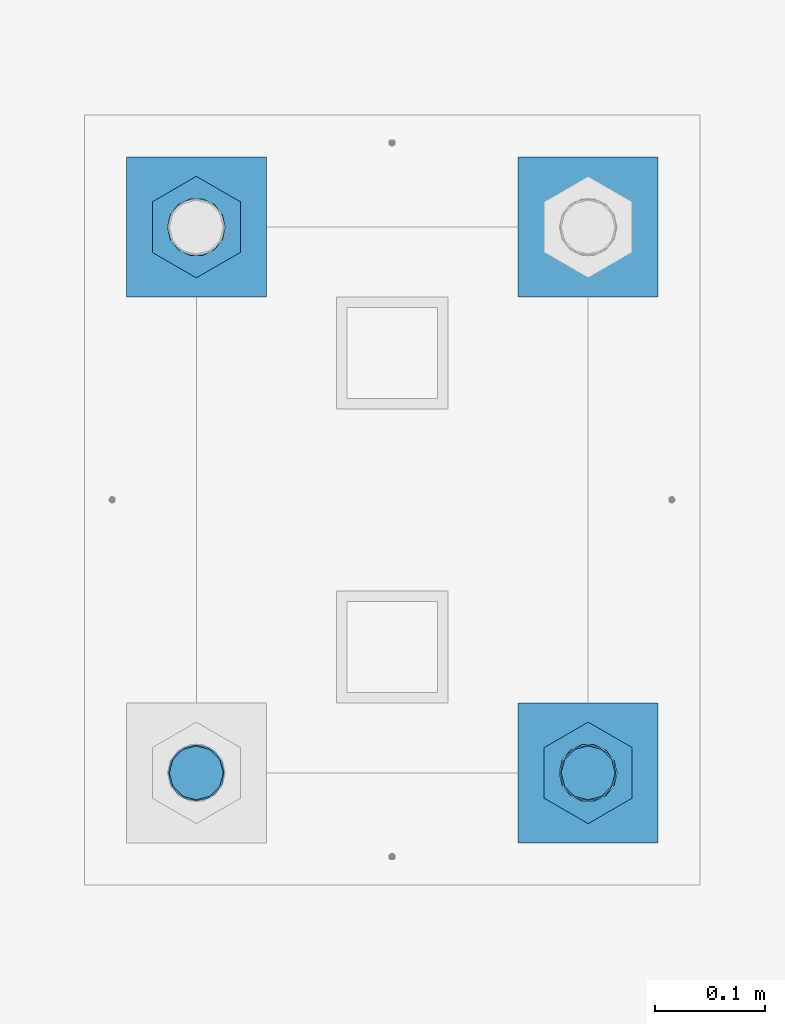
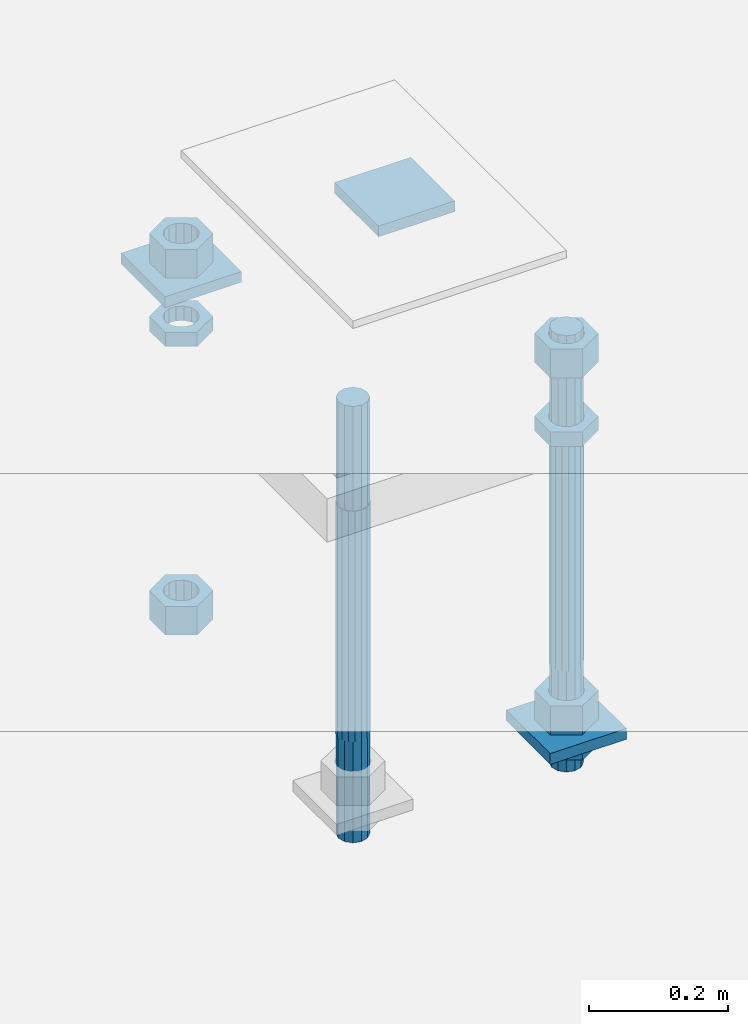
# One storey, part 2766 of 3843: 12 beams, 1 element without a shape of its own.
"""IFC2X3 building model written with IfcOpenShell, lengths in millimetres."""

import ifcopenshell
import ifcopenshell.guid

model = None  # the IFC model being written
_history = None  # IfcOwnerHistory: only IFC2X3 demands one
_inside = {}  # id of a spatial element -> (the spatial element, [elements in it])
_under = {}  # id of a project, library or spatial element -> (it, [spatial elements below it])
_declared = {}  # id of a project -> (the project, [libraries it declares])
_typed = {}  # id of a type object -> (the type object, [elements of that type])
_made_of = {}  # id of a material, layer set ... -> (it, [elements and type objects made of it])


def new_model(schema):
    """Start an empty IFC model of exactly this schema.

    Asked for "IFC4X3", IfcOpenShell would pick the latest addendum, in which some entities
    have other attributes; the version numbers below select the first issue.
    IFC2X3 requires an IfcOwnerHistory on every rooted entity: one is made here for all.
    """
    global model, _history
    if schema == "IFC4X3":
        model = ifcopenshell.file(schema_version=(4, 3, 0, 0))
    else:
        model = ifcopenshell.file(schema=schema)
    _inside.clear()
    _under.clear()
    _declared.clear()
    _typed.clear()
    _made_of.clear()
    _history = None
    if model.schema == "IFC2X3":
        org = make("IfcOrganization", Name="unknown")
        user = make(
            "IfcPersonAndOrganization",
            ThePerson=make("IfcPerson", FamilyName="unknown"),
            TheOrganization=org,
        )
        app = make(
            "IfcApplication",
            ApplicationDeveloper=org,
            Version="unknown",
            ApplicationFullName="unknown",
            ApplicationIdentifier="unknown",
        )
        _history = make(
            "IfcOwnerHistory",
            OwningUser=user,
            OwningApplication=app,
            ChangeAction="ADDED",
            CreationDate=0,
        )
    return model


def make(cls, **values):
    """One entity of the class cls with the attributes given. An attribute that is None is left unset."""
    return model.create_entity(
        cls, **{name: value for name, value in values.items() if value is not None}
    )


def rooted(cls, **values):
    """An entity with a GlobalId (a new one), such as an element, a storey or a relation."""
    return make(cls, GlobalId=ifcopenshell.guid.new(), OwnerHistory=_history, **values)


def si_unit(unit_type, name, prefix=None):
    """IfcSIUnit, for example si_unit("LENGTHUNIT", "METRE", prefix="MILLI")."""
    return make("IfcSIUnit", UnitType=unit_type, Prefix=prefix, Name=name)


def assignment(units):
    """IfcUnitAssignment: the units of a project."""
    return None if units is None else make("IfcUnitAssignment", Units=units)


def point(xyz):
    """IfcCartesianPoint."""
    return None if xyz is None else make("IfcCartesianPoint", Coordinates=xyz)


def direction(xyz):
    """IfcDirection."""
    return None if xyz is None else make("IfcDirection", DirectionRatios=xyz)


def frame(location, z_axis=None, x_axis=None):
    """IfcAxis2Placement3D, a coordinate frame: its origin and axes. An axis left out is left unset."""
    return make(
        "IfcAxis2Placement3D",
        Location=point(location),
        Axis=direction(z_axis),
        RefDirection=direction(x_axis),
    )


def origin_with_axes():
    """The frame at (0, 0, 0) with the z axis (0, 0, 1) and the x axis (1, 0, 0) written out."""
    return frame((0.0, 0.0, 0.0), z_axis=(0.0, 0.0, 1.0), x_axis=(1.0, 0.0, 0.0))


def place(relative_to, where):
    """IfcLocalPlacement: puts the frame where relative to a parent placement (None: the world)."""
    return make(
        "IfcLocalPlacement", PlacementRelTo=relative_to, RelativePlacement=where
    )


def context(
    kind, dimensions, precision=None, world=None, true_north=None, identifier=None
):
    """IfcGeometricRepresentationContext, for example the 3D "Model" context."""
    return make(
        "IfcGeometricRepresentationContext",
        ContextIdentifier=identifier,
        ContextType=kind,
        CoordinateSpaceDimension=dimensions,
        Precision=precision,
        WorldCoordinateSystem=world,
        TrueNorth=true_north,
    )


def subcontext(parent, identifier, kind, view, scale=None):
    """IfcGeometricRepresentationSubContext, for example "Body" below "Model"."""
    return make(
        "IfcGeometricRepresentationSubContext",
        ContextIdentifier=identifier,
        ContextType=kind,
        ParentContext=parent,
        TargetScale=scale,
        TargetView=view,
    )


def project(units=None, contexts=None):
    """IfcProject with its units and contexts."""
    return rooted(
        "IfcProject",
        Name="project",
        RepresentationContexts=contexts,
        UnitsInContext=assignment(units),
    )


def spatial(cls, under=None, at=None, **own):
    """A site, building, storey or space (cls), placed at a placement, below another one or the project."""
    s = rooted(cls, ObjectPlacement=at, **own)
    if under is not None:
        _under.setdefault(under.id(), (under, []))[1].append(s)
    return s


def faces_of(points, faces, orient=None, outer=None):
    """IfcFace entities. A face is a list of loops; a loop is a list of indices into points, from 0.

    orient and outer hold one flag for each loop. By default every Orientation is true, the
    first loop of a face is its IfcFaceOuterBound and the others are IfcFaceBound.
    """
    made = []
    for i, loops in enumerate(faces):
        bounds = []
        for j, loop in enumerate(loops):
            is_outer = j == 0 if outer is None else outer[i][j]
            bounds.append(
                make(
                    "IfcFaceOuterBound" if is_outer else "IfcFaceBound",
                    Bound=make("IfcPolyLoop", Polygon=[points[k] for k in loop]),
                    Orientation=True if orient is None else orient[i][j],
                )
            )
        made.append(make("IfcFace", Bounds=bounds))
    return made


def faceted_brep(points, faces, orient=None, outer=None, voids=None):
    """IfcFacetedBrep: a solid bounded by flat faces; with voids (closed shells), ...WithVoids."""
    shared = [point(p) for p in points]
    hull = make("IfcClosedShell", CfsFaces=faces_of(shared, faces, orient, outer))
    if voids is None:
        return make("IfcFacetedBrep", Outer=hull)
    return make(
        "IfcFacetedBrepWithVoids",
        Outer=hull,
        Voids=[
            make(cls, CfsFaces=faces_of(shared, fs, o, b)) for cls, fs, o, b in voids
        ],
    )


def shape(context_of_items, identifier, shape_type, items):
    """IfcShapeRepresentation: the items that make up one representation, for example the "Body"."""
    return make(
        "IfcShapeRepresentation",
        ContextOfItems=context_of_items,
        RepresentationIdentifier=identifier,
        RepresentationType=shape_type,
        Items=items,
    )


def material(Name=None, Category=None):
    """IfcMaterial."""
    return make("IfcMaterial", Name=Name, Category=Category)


def made_of(thing, what):
    """Note that an element or type object is made of a material, layer set ...; save() writes the relation."""
    if what is not None:
        _made_of.setdefault(what.id(), (what, []))[1].append(thing)
    return thing


def type_object(cls, material=None, **own):
    """A type object (cls), such as IfcWallType, which elements share."""
    return made_of(rooted(cls, **own), material)


def element(
    cls,
    number,
    at=None,
    inside=None,
    cuts=None,
    type_object=None,
    material=None,
    context=None,
    identifier="Body",
    shape_type=None,
    held_by="IfcProductDefinitionShape",
    body=None,
    shapes=None,
    **own,
):
    """One element of the class cls, such as IfcWall. Its Tag is "e" and its number.

    at: its placement. inside: the storey or other place that contains it. cuts: it is an
    opening in that element (IfcRelVoidsElement). A single representation is given by context,
    identifier, shape_type and body (its items); several are given by shapes. held_by: the class
    of the entity that holds the representations. save() writes the other relations.
    """
    e = rooted(cls, Tag="e%d" % number, ObjectPlacement=at, **own)
    if body is not None:
        shapes = [shape(context, identifier, shape_type, body)]
    if shapes is not None:
        e.Representation = make(held_by, Representations=shapes)
    if inside is not None:
        _inside.setdefault(inside.id(), (inside, []))[1].append(e)
    if cuts is not None:
        rooted(
            "IfcRelVoidsElement", RelatingBuildingElement=cuts, RelatedOpeningElement=e
        )
    if type_object is not None:
        _typed.setdefault(type_object.id(), (type_object, []))[1].append(e)
    return made_of(e, material)


def aggregate(whole, parts):
    """IfcRelAggregates: a whole, such as a stair, and the parts it consists of."""
    return rooted("IfcRelAggregates", RelatingObject=whole, RelatedObjects=parts)


def save(model, path):
    """Write the relations noted so far, then the file.

    IfcRelAggregates (storeys below a building ...), IfcRelContainedInSpatialStructure (elements
    in a storey), IfcRelDefinesByType, IfcRelAssociatesMaterial and IfcRelDeclares: one each for
    every whole, place, type object, material and project.
    """
    for whole, parts in _under.values():
        aggregate(whole, parts)
    for where, things in _inside.values():
        rooted(
            "IfcRelContainedInSpatialStructure",
            RelatedElements=things,
            RelatingStructure=where,
        )
    for kind, things in _typed.values():
        rooted("IfcRelDefinesByType", RelatedObjects=things, RelatingType=kind)
    for what, things in _made_of.values():
        rooted("IfcRelAssociatesMaterial", RelatedObjects=things, RelatingMaterial=what)
    for by, libraries in _declared.values():
        rooted("IfcRelDeclares", RelatingContext=by, RelatedDefinitions=libraries)
    model.write(path)


model = new_model("IFC2X3")

# Units and contexts
model_context = context("Model", 3, precision=1e-05, world=origin_with_axes())
body_context = subcontext(model_context, "Body", "Model", "MODEL_VIEW")
ifc_project = project(units=[si_unit("LENGTHUNIT", "METRE", prefix="MILLI"), si_unit("AREAUNIT", "SQUARE_METRE"), si_unit("VOLUMEUNIT", "CUBIC_METRE"), si_unit("MASSUNIT", "GRAM", prefix="KILO"), si_unit("TIMEUNIT", "SECOND"), si_unit("PLANEANGLEUNIT", "RADIAN"), si_unit("SOLIDANGLEUNIT", "STERADIAN"), si_unit("THERMODYNAMICTEMPERATUREUNIT", "DEGREE_CELSIUS"), si_unit("LUMINOUSINTENSITYUNIT", "LUMEN")], contexts=[model_context])

# Site, building, storey
site_placement = place(None, origin_with_axes())
site = spatial("IfcSite", under=ifc_project, at=site_placement, CompositionType="ELEMENT")
building_placement = place(site_placement, origin_with_axes())
building = spatial("IfcBuilding", under=site, at=building_placement, Name="Undefined", CompositionType="ELEMENT")
storey_placement = place(building_placement, origin_with_axes())
storey = spatial("IfcBuildingStorey", under=building, at=storey_placement, Name="Undefined", CompositionType="ELEMENT", Elevation=0.0)

# Assembly, beams
assembly_placement = place(storey_placement, origin_with_axes())
assembly = element("IfcElementAssembly", 1, at=assembly_placement, inside=storey, Name="TEMPLATE", AssemblyPlace="NOTDEFINED", PredefinedType="RIGID_FRAME")
ifc_material_1 = material(Name="STEEL/A572-50")
beam_type_1 = type_object("IfcBeamType", PredefinedType="NOTDEFINED")
beam_1_placement = place(assembly_placement, frame((115862.100001526, 52952.65, 29873.575), z_axis=(0.0, -1.0, 0.0), x_axis=(1.0, 0.0, 0.0)))
beam_1 = element("IfcBeam", 2, at=beam_1_placement, type_object=beam_type_1, material=ifc_material_1, Name="WASHER_PLATE", context=body_context, shape_type="Brep", body=[
    faceted_brep([(0.0, 9.52500000000146, -63.5), (0.0, 9.52500000000146, 63.5), (127.0, 9.52500000000146, 63.5), (127.0, 9.52500000000146, -63.5), (0.0, -9.52500000000146, 63.5), (127.0, -9.52500000000146, 63.5), (0.0, -9.52500000000146, -63.5), (127.0, -9.52500000000146, -63.5)], [[[0, 1, 2, 3]], [[1, 4, 5, 2]], [[4, 6, 7, 5]], [[6, 0, 3, 7]], [[5, 7, 3, 2]], [[6, 4, 1, 0]]]),
])
beam_2_placement = place(assembly_placement, frame((116217.700001526, 52952.65, 29873.575), z_axis=(0.0, -1.0, 0.0), x_axis=(1.0, 0.0, 0.0)))
beam_2 = element("IfcBeam", 3, at=beam_2_placement, type_object=beam_type_1, material=ifc_material_1, Name="WASHER_PLATE", context=body_context, shape_type="Brep", body=[
    faceted_brep([(0.0, 9.52500000000146, -63.5), (0.0, 9.52500000000146, 63.5), (127.0, 9.52500000000146, 63.5), (127.0, 9.52500000000146, -63.5), (0.0, -9.52500000000146, 63.5), (127.0, -9.52500000000146, 63.5), (0.0, -9.52500000000146, -63.5), (127.0, -9.52500000000146, -63.5)], [[[0, 1, 2, 3]], [[1, 4, 5, 2]], [[4, 6, 7, 5]], [[6, 0, 3, 7]], [[5, 7, 3, 2]], [[6, 4, 1, 0]]]),
])
beam_3_placement = place(assembly_placement, frame((116217.700001526, 52457.35, 29244.925), z_axis=(0.0, -1.0, 0.0), x_axis=(1.0, 0.0, 0.0)))
beam_3 = element("IfcBeam", 4, at=beam_3_placement, type_object=beam_type_1, material=ifc_material_1, Name="WASHER_PLATE", context=body_context, shape_type="Brep", body=[
    faceted_brep([(0.0, 9.52500000000146, -63.5), (0.0, 9.52500000000146, 63.5), (127.0, 9.52500000000146, 63.5), (127.0, 9.52500000000146, -63.5), (0.0, -9.52500000000146, 63.5), (127.0, -9.52500000000146, 63.5), (0.0, -9.52500000000146, -63.5), (127.0, -9.52500000000146, -63.5)], [[[0, 1, 2, 3]], [[1, 4, 5, 2]], [[4, 6, 7, 5]], [[6, 0, 3, 7]], [[5, 7, 3, 2]], [[6, 4, 1, 0]]]),
])
ifc_material_2 = material(Name="STEEL/A36")
beam_type_2 = type_object("IfcBeamType", Name="2_HALF_NUT", PredefinedType="NOTDEFINED")
beam_4_placement = place(assembly_placement, frame((115925.600001526, 52952.65, 29787.85), z_axis=(1.0, 0.0, 0.0), x_axis=(0.0, 0.0, -1.0)))
beam_4 = element("IfcBeam", 5, at=beam_4_placement, type_object=beam_type_2, material=ifc_material_2, Name="NUT", ObjectType="2_HALF_NUT", context=body_context, shape_type="Brep", body=[
    faceted_brep([(0.0, -46.0369987487793, 0.0), (0.0, -23.0184993743896, -39.869213104248), (25.4000000000015, -23.0184993743896, -39.869213104248), (25.4000000000015, -46.0369987487793, 0.0), (0.0, 23.0184993743896, -39.869213104248), (25.4000000000015, 23.0184993743896, -39.869213104248), (0.0, 46.0369987487793, 0.0), (25.4000000000015, 46.0369987487793, 0.0), (0.0, 23.0184993743896, 39.869213104248), (25.4000000000015, 23.0184993743896, 39.869213104248), (0.0, -23.0184993743896, 39.869213104248), (25.4000000000015, -23.0184993743896, 39.869213104248), (0.0, 0.0, 26.1940002441406), (0.0, 11.3650617044477, 23.5999013092805), (25.4000000000015, 11.3650617044477, 23.5999013092805), (25.4000000000015, 0.0, 26.1940002441406), (0.0, 20.4791109456419, 16.3316083006721), (25.4000000000015, 20.4791109456419, 16.3316083006721), (0.0, 25.5370200498292, 5.82867859874386), (25.4000000000015, 25.5370200498292, 5.82867859874386), (0.0, 25.5370200498292, -5.82867859874386), (25.4000000000015, 25.5370200498292, -5.82867859874386), (0.0, 20.4791109456419, -16.3316083006721), (25.4000000000015, 20.4791109456419, -16.3316083006721), (0.0, 11.3650617044477, -23.5999013092805), (25.4000000000015, 11.3650617044477, -23.5999013092805), (0.0, 0.0, -26.1940002441406), (25.4000000000015, 0.0, -26.1940002441406), (0.0, -11.3650617044477, -23.5999013092805), (25.4000000000015, -11.3650617044477, -23.5999013092805), (0.0, -20.4791109456419, -16.3316083006721), (25.4000000000015, -20.4791109456419, -16.3316083006721), (0.0, -25.5370200498292, -5.82867859874386), (25.4000000000015, -25.5370200498292, -5.82867859874386), (0.0, -25.5370200498292, 5.82867859874386), (25.4000000000015, -25.5370200498292, 5.82867859874386), (0.0, -20.4791109456419, 16.3316083006721), (25.4000000000015, -20.4791109456419, 16.3316083006721), (0.0, -11.3650617044477, 23.5999013092805), (25.4000000000015, -11.3650617044477, 23.5999013092805)], [[[0, 1, 2, 3]], [[1, 4, 5, 2]], [[4, 6, 7, 5]], [[6, 8, 9, 7]], [[8, 10, 11, 9]], [[10, 0, 3, 11]], [[12, 13, 14, 15]], [[13, 16, 17, 14]], [[16, 18, 19, 17]], [[18, 20, 21, 19]], [[20, 22, 23, 21]], [[22, 24, 25, 23]], [[24, 26, 27, 25]], [[26, 28, 29, 27]], [[28, 30, 31, 29]], [[30, 32, 33, 31]], [[32, 34, 35, 33]], [[34, 36, 37, 35]], [[36, 38, 39, 37]], [[38, 12, 15, 39]], [[5, 7, 9, 11, 3, 2], [17, 19, 21, 23, 25, 27, 29, 31, 33, 35, 37, 39, 15, 14]], [[10, 8, 6, 4, 1, 0], [38, 36, 34, 32, 30, 28, 26, 24, 22, 20, 18, 16, 13, 12]]]),
])
beam_5_placement = place(assembly_placement, frame((116281.200001526, 52457.35, 29787.85), z_axis=(1.0, 0.0, 0.0), x_axis=(0.0, 0.0, -1.0)))
beam_5 = element("IfcBeam", 6, at=beam_5_placement, type_object=beam_type_2, material=ifc_material_2, Name="NUT", ObjectType="2_HALF_NUT", context=body_context, shape_type="Brep", body=[
    faceted_brep([(0.0, -46.0369987487793, 0.0), (0.0, -23.0184993743896, -39.869213104248), (25.4000000000015, -23.0184993743896, -39.869213104248), (25.4000000000015, -46.0369987487793, 0.0), (0.0, 23.0184993743896, -39.869213104248), (25.4000000000015, 23.0184993743896, -39.869213104248), (0.0, 46.0369987487793, 0.0), (25.4000000000015, 46.0369987487793, 0.0), (0.0, 23.0184993743896, 39.869213104248), (25.4000000000015, 23.0184993743896, 39.869213104248), (0.0, -23.0184993743896, 39.869213104248), (25.4000000000015, -23.0184993743896, 39.869213104248), (0.0, 0.0, 26.1940002441406), (0.0, 11.3650617044477, 23.5999013092805), (25.4000000000015, 11.3650617044477, 23.5999013092805), (25.4000000000015, 0.0, 26.1940002441406), (0.0, 20.4791109456419, 16.3316083006721), (25.4000000000015, 20.4791109456419, 16.3316083006721), (0.0, 25.5370200498292, 5.82867859874386), (25.4000000000015, 25.5370200498292, 5.82867859874386), (0.0, 25.5370200498292, -5.82867859874386), (25.4000000000015, 25.5370200498292, -5.82867859874386), (0.0, 20.4791109456419, -16.3316083006721), (25.4000000000015, 20.4791109456419, -16.3316083006721), (0.0, 11.3650617044477, -23.5999013092805), (25.4000000000015, 11.3650617044477, -23.5999013092805), (0.0, 0.0, -26.1940002441406), (25.4000000000015, 0.0, -26.1940002441406), (0.0, -11.3650617044477, -23.5999013092805), (25.4000000000015, -11.3650617044477, -23.5999013092805), (0.0, -20.4791109456419, -16.3316083006721), (25.4000000000015, -20.4791109456419, -16.3316083006721), (0.0, -25.5370200498292, -5.82867859874386), (25.4000000000015, -25.5370200498292, -5.82867859874386), (0.0, -25.5370200498292, 5.82867859874386), (25.4000000000015, -25.5370200498292, 5.82867859874386), (0.0, -20.4791109456419, 16.3316083006721), (25.4000000000015, -20.4791109456419, 16.3316083006721), (0.0, -11.3650617044477, 23.5999013092805), (25.4000000000015, -11.3650617044477, 23.5999013092805)], [[[0, 1, 2, 3]], [[1, 4, 5, 2]], [[4, 6, 7, 5]], [[6, 8, 9, 7]], [[8, 10, 11, 9]], [[10, 0, 3, 11]], [[12, 13, 14, 15]], [[13, 16, 17, 14]], [[16, 18, 19, 17]], [[18, 20, 21, 19]], [[20, 22, 23, 21]], [[22, 24, 25, 23]], [[24, 26, 27, 25]], [[26, 28, 29, 27]], [[28, 30, 31, 29]], [[30, 32, 33, 31]], [[32, 34, 35, 33]], [[34, 36, 37, 35]], [[36, 38, 39, 37]], [[38, 12, 15, 39]], [[5, 7, 9, 11, 3, 2], [17, 19, 21, 23, 25, 27, 29, 31, 33, 35, 37, 39, 15, 14]], [[10, 8, 6, 4, 1, 0], [38, 36, 34, 32, 30, 28, 26, 24, 22, 20, 18, 16, 13, 12]]]),
])
beam_6_placement = place(assembly_placement, frame((116281.200001526, 52457.35, 29235.4), z_axis=(1.0, 0.0, 0.0), x_axis=(0.0, 0.0, -1.0)))
beam_6 = element("IfcBeam", 7, at=beam_6_placement, type_object=beam_type_2, material=ifc_material_2, Name="NUT", ObjectType="2_HALF_NUT", context=body_context, shape_type="Brep", body=[
    faceted_brep([(0.0, -46.0369987487793, 0.0), (0.0, -23.0184993743896, -39.869213104248), (25.4000000000015, -23.0184993743896, -39.869213104248), (25.4000000000015, -46.0369987487793, 0.0), (0.0, 23.0184993743896, -39.869213104248), (25.4000000000015, 23.0184993743896, -39.869213104248), (0.0, 46.0369987487793, 0.0), (25.4000000000015, 46.0369987487793, 0.0), (0.0, 23.0184993743896, 39.869213104248), (25.4000000000015, 23.0184993743896, 39.869213104248), (0.0, -23.0184993743896, 39.869213104248), (25.4000000000015, -23.0184993743896, 39.869213104248), (0.0, 0.0, 26.1940002441406), (0.0, 11.3650617044477, 23.5999013092805), (25.4000000000015, 11.3650617044477, 23.5999013092805), (25.4000000000015, 0.0, 26.1940002441406), (0.0, 20.4791109456419, 16.3316083006721), (25.4000000000015, 20.4791109456419, 16.3316083006721), (0.0, 25.5370200498292, 5.82867859874386), (25.4000000000015, 25.5370200498292, 5.82867859874386), (0.0, 25.5370200498292, -5.82867859874386), (25.4000000000015, 25.5370200498292, -5.82867859874386), (0.0, 20.4791109456419, -16.3316083006721), (25.4000000000015, 20.4791109456419, -16.3316083006721), (0.0, 11.3650617044477, -23.5999013092805), (25.4000000000015, 11.3650617044477, -23.5999013092805), (0.0, 0.0, -26.1940002441406), (25.4000000000015, 0.0, -26.1940002441406), (0.0, -11.3650617044477, -23.5999013092805), (25.4000000000015, -11.3650617044477, -23.5999013092805), (0.0, -20.4791109456419, -16.3316083006721), (25.4000000000015, -20.4791109456419, -16.3316083006721), (0.0, -25.5370200498292, -5.82867859874386), (25.4000000000015, -25.5370200498292, -5.82867859874386), (0.0, -25.5370200498292, 5.82867859874386), (25.4000000000015, -25.5370200498292, 5.82867859874386), (0.0, -20.4791109456419, 16.3316083006721), (25.4000000000015, -20.4791109456419, 16.3316083006721), (0.0, -11.3650617044477, 23.5999013092805), (25.4000000000015, -11.3650617044477, 23.5999013092805)], [[[0, 1, 2, 3]], [[1, 4, 5, 2]], [[4, 6, 7, 5]], [[6, 8, 9, 7]], [[8, 10, 11, 9]], [[10, 0, 3, 11]], [[12, 13, 14, 15]], [[13, 16, 17, 14]], [[16, 18, 19, 17]], [[18, 20, 21, 19]], [[20, 22, 23, 21]], [[22, 24, 25, 23]], [[24, 26, 27, 25]], [[26, 28, 29, 27]], [[28, 30, 31, 29]], [[30, 32, 33, 31]], [[32, 34, 35, 33]], [[34, 36, 37, 35]], [[36, 38, 39, 37]], [[38, 12, 15, 39]], [[5, 7, 9, 11, 3, 2], [17, 19, 21, 23, 25, 27, 29, 31, 33, 35, 37, 39, 15, 14]], [[10, 8, 6, 4, 1, 0], [38, 36, 34, 32, 30, 28, 26, 24, 22, 20, 18, 16, 13, 12]]]),
])
beam_type_3 = type_object("IfcBeamType", Name="2_HEAVY_HEX_NUT", PredefinedType="NOTDEFINED")
beam_7_placement = place(assembly_placement, frame((115925.600001526, 52952.65, 29933.9), z_axis=(1.0, 0.0, 0.0), x_axis=(0.0, 0.0, -1.0)))
beam_7 = element("IfcBeam", 8, at=beam_7_placement, type_object=beam_type_3, material=ifc_material_2, Name="NUT", ObjectType="2_HEAVY_HEX_NUT", context=body_context, shape_type="Brep", body=[
    faceted_brep([(0.0, -46.0369987487793, 0.0), (0.0, -23.0184993743896, -39.869213104248), (50.7999999999993, -23.0184993743896, -39.869213104248), (50.7999999999993, -46.0369987487793, 0.0), (0.0, 23.0184993743896, -39.869213104248), (50.7999999999993, 23.0184993743896, -39.869213104248), (0.0, 46.0369987487793, 0.0), (50.7999999999993, 46.0369987487793, 0.0), (0.0, 23.0184993743896, 39.869213104248), (50.7999999999993, 23.0184993743896, 39.869213104248), (0.0, -23.0184993743896, 39.869213104248), (50.7999999999993, -23.0184993743896, 39.869213104248), (0.0, 0.0, 26.1940002441406), (0.0, 11.3650617044477, 23.5999013092805), (50.7999999999993, 11.3650617044477, 23.5999013092805), (50.7999999999993, 0.0, 26.1940002441406), (0.0, 20.4791109456419, 16.3316083006721), (50.7999999999993, 20.4791109456419, 16.3316083006721), (0.0, 25.5370200498292, 5.82867859874386), (50.7999999999993, 25.5370200498292, 5.82867859874386), (0.0, 25.5370200498292, -5.82867859874386), (50.7999999999993, 25.5370200498292, -5.82867859874386), (0.0, 20.4791109456419, -16.3316083006721), (50.7999999999993, 20.4791109456419, -16.3316083006721), (0.0, 11.3650617044477, -23.5999013092805), (50.7999999999993, 11.3650617044477, -23.5999013092805), (0.0, 0.0, -26.1940002441406), (50.7999999999993, 0.0, -26.1940002441406), (0.0, -11.3650617044477, -23.5999013092805), (50.7999999999993, -11.3650617044477, -23.5999013092805), (0.0, -20.4791109456419, -16.3316083006721), (50.7999999999993, -20.4791109456419, -16.3316083006721), (0.0, -25.5370200498292, -5.82867859874386), (50.7999999999993, -25.5370200498292, -5.82867859874386), (0.0, -25.5370200498292, 5.82867859874386), (50.7999999999993, -25.5370200498292, 5.82867859874386), (0.0, -20.4791109456419, 16.3316083006721), (50.7999999999993, -20.4791109456419, 16.3316083006721), (0.0, -11.3650617044477, 23.5999013092805), (50.7999999999993, -11.3650617044477, 23.5999013092805)], [[[0, 1, 2, 3]], [[1, 4, 5, 2]], [[4, 6, 7, 5]], [[6, 8, 9, 7]], [[8, 10, 11, 9]], [[10, 0, 3, 11]], [[12, 13, 14, 15]], [[13, 16, 17, 14]], [[16, 18, 19, 17]], [[18, 20, 21, 19]], [[20, 22, 23, 21]], [[22, 24, 25, 23]], [[24, 26, 27, 25]], [[26, 28, 29, 27]], [[28, 30, 31, 29]], [[30, 32, 33, 31]], [[32, 34, 35, 33]], [[34, 36, 37, 35]], [[36, 38, 39, 37]], [[38, 12, 15, 39]], [[5, 7, 9, 11, 3, 2], [17, 19, 21, 23, 25, 27, 29, 31, 33, 35, 37, 39, 15, 14]], [[10, 8, 6, 4, 1, 0], [38, 36, 34, 32, 30, 28, 26, 24, 22, 20, 18, 16, 13, 12]]]),
])
beam_8_placement = place(assembly_placement, frame((115925.600001526, 52952.65, 29305.25), z_axis=(1.0, 0.0, 0.0), x_axis=(0.0, 0.0, -1.0)))
beam_8 = element("IfcBeam", 9, at=beam_8_placement, type_object=beam_type_3, material=ifc_material_2, Name="NUT", ObjectType="2_HEAVY_HEX_NUT", context=body_context, shape_type="Brep", body=[
    faceted_brep([(0.0, -46.0369987487793, 0.0), (0.0, -23.0184993743896, -39.869213104248), (50.7999999999993, -23.0184993743896, -39.869213104248), (50.7999999999993, -46.0369987487793, 0.0), (0.0, 23.0184993743896, -39.869213104248), (50.7999999999993, 23.0184993743896, -39.869213104248), (0.0, 46.0369987487793, 0.0), (50.7999999999993, 46.0369987487793, 0.0), (0.0, 23.0184993743896, 39.869213104248), (50.7999999999993, 23.0184993743896, 39.869213104248), (0.0, -23.0184993743896, 39.869213104248), (50.7999999999993, -23.0184993743896, 39.869213104248), (0.0, 0.0, 26.1940002441406), (0.0, 11.3650617044477, 23.5999013092805), (50.7999999999993, 11.3650617044477, 23.5999013092805), (50.7999999999993, 0.0, 26.1940002441406), (0.0, 20.4791109456419, 16.3316083006721), (50.7999999999993, 20.4791109456419, 16.3316083006721), (0.0, 25.5370200498292, 5.82867859874386), (50.7999999999993, 25.5370200498292, 5.82867859874386), (0.0, 25.5370200498292, -5.82867859874386), (50.7999999999993, 25.5370200498292, -5.82867859874386), (0.0, 20.4791109456419, -16.3316083006721), (50.7999999999993, 20.4791109456419, -16.3316083006721), (0.0, 11.3650617044477, -23.5999013092805), (50.7999999999993, 11.3650617044477, -23.5999013092805), (0.0, 0.0, -26.1940002441406), (50.7999999999993, 0.0, -26.1940002441406), (0.0, -11.3650617044477, -23.5999013092805), (50.7999999999993, -11.3650617044477, -23.5999013092805), (0.0, -20.4791109456419, -16.3316083006721), (50.7999999999993, -20.4791109456419, -16.3316083006721), (0.0, -25.5370200498292, -5.82867859874386), (50.7999999999993, -25.5370200498292, -5.82867859874386), (0.0, -25.5370200498292, 5.82867859874386), (50.7999999999993, -25.5370200498292, 5.82867859874386), (0.0, -20.4791109456419, 16.3316083006721), (50.7999999999993, -20.4791109456419, 16.3316083006721), (0.0, -11.3650617044477, 23.5999013092805), (50.7999999999993, -11.3650617044477, 23.5999013092805)], [[[0, 1, 2, 3]], [[1, 4, 5, 2]], [[4, 6, 7, 5]], [[6, 8, 9, 7]], [[8, 10, 11, 9]], [[10, 0, 3, 11]], [[12, 13, 14, 15]], [[13, 16, 17, 14]], [[16, 18, 19, 17]], [[18, 20, 21, 19]], [[20, 22, 23, 21]], [[22, 24, 25, 23]], [[24, 26, 27, 25]], [[26, 28, 29, 27]], [[28, 30, 31, 29]], [[30, 32, 33, 31]], [[32, 34, 35, 33]], [[34, 36, 37, 35]], [[36, 38, 39, 37]], [[38, 12, 15, 39]], [[5, 7, 9, 11, 3, 2], [17, 19, 21, 23, 25, 27, 29, 31, 33, 35, 37, 39, 15, 14]], [[10, 8, 6, 4, 1, 0], [38, 36, 34, 32, 30, 28, 26, 24, 22, 20, 18, 16, 13, 12]]]),
])
beam_9_placement = place(assembly_placement, frame((116281.200001526, 52457.35, 29933.9), z_axis=(1.0, 0.0, 0.0), x_axis=(0.0, 0.0, -1.0)))
beam_9 = element("IfcBeam", 10, at=beam_9_placement, type_object=beam_type_3, material=ifc_material_2, Name="NUT", ObjectType="2_HEAVY_HEX_NUT", context=body_context, shape_type="Brep", body=[
    faceted_brep([(0.0, -46.0369987487793, 0.0), (0.0, -23.0184993743896, -39.869213104248), (50.7999999999993, -23.0184993743896, -39.869213104248), (50.7999999999993, -46.0369987487793, 0.0), (0.0, 23.0184993743896, -39.869213104248), (50.7999999999993, 23.0184993743896, -39.869213104248), (0.0, 46.0369987487793, 0.0), (50.7999999999993, 46.0369987487793, 0.0), (0.0, 23.0184993743896, 39.869213104248), (50.7999999999993, 23.0184993743896, 39.869213104248), (0.0, -23.0184993743896, 39.869213104248), (50.7999999999993, -23.0184993743896, 39.869213104248), (0.0, 0.0, 26.1940002441406), (0.0, 11.3650617044477, 23.5999013092805), (50.7999999999993, 11.3650617044477, 23.5999013092805), (50.7999999999993, 0.0, 26.1940002441406), (0.0, 20.4791109456419, 16.3316083006721), (50.7999999999993, 20.4791109456419, 16.3316083006721), (0.0, 25.5370200498292, 5.82867859874386), (50.7999999999993, 25.5370200498292, 5.82867859874386), (0.0, 25.5370200498292, -5.82867859874386), (50.7999999999993, 25.5370200498292, -5.82867859874386), (0.0, 20.4791109456419, -16.3316083006721), (50.7999999999993, 20.4791109456419, -16.3316083006721), (0.0, 11.3650617044477, -23.5999013092805), (50.7999999999993, 11.3650617044477, -23.5999013092805), (0.0, 0.0, -26.1940002441406), (50.7999999999993, 0.0, -26.1940002441406), (0.0, -11.3650617044477, -23.5999013092805), (50.7999999999993, -11.3650617044477, -23.5999013092805), (0.0, -20.4791109456419, -16.3316083006721), (50.7999999999993, -20.4791109456419, -16.3316083006721), (0.0, -25.5370200498292, -5.82867859874386), (50.7999999999993, -25.5370200498292, -5.82867859874386), (0.0, -25.5370200498292, 5.82867859874386), (50.7999999999993, -25.5370200498292, 5.82867859874386), (0.0, -20.4791109456419, 16.3316083006721), (50.7999999999993, -20.4791109456419, 16.3316083006721), (0.0, -11.3650617044477, 23.5999013092805), (50.7999999999993, -11.3650617044477, 23.5999013092805)], [[[0, 1, 2, 3]], [[1, 4, 5, 2]], [[4, 6, 7, 5]], [[6, 8, 9, 7]], [[8, 10, 11, 9]], [[10, 0, 3, 11]], [[12, 13, 14, 15]], [[13, 16, 17, 14]], [[16, 18, 19, 17]], [[18, 20, 21, 19]], [[20, 22, 23, 21]], [[22, 24, 25, 23]], [[24, 26, 27, 25]], [[26, 28, 29, 27]], [[28, 30, 31, 29]], [[30, 32, 33, 31]], [[32, 34, 35, 33]], [[34, 36, 37, 35]], [[36, 38, 39, 37]], [[38, 12, 15, 39]], [[5, 7, 9, 11, 3, 2], [17, 19, 21, 23, 25, 27, 29, 31, 33, 35, 37, 39, 15, 14]], [[10, 8, 6, 4, 1, 0], [38, 36, 34, 32, 30, 28, 26, 24, 22, 20, 18, 16, 13, 12]]]),
])
beam_10_placement = place(assembly_placement, frame((116281.200001526, 52457.35, 29305.25), z_axis=(1.0, 0.0, 0.0), x_axis=(0.0, 0.0, -1.0)))
beam_10 = element("IfcBeam", 11, at=beam_10_placement, type_object=beam_type_3, material=ifc_material_2, Name="NUT", ObjectType="2_HEAVY_HEX_NUT", context=body_context, shape_type="Brep", body=[
    faceted_brep([(0.0, -46.0369987487793, 0.0), (0.0, -23.0184993743896, -39.869213104248), (50.7999999999993, -23.0184993743896, -39.869213104248), (50.7999999999993, -46.0369987487793, 0.0), (0.0, 23.0184993743896, -39.869213104248), (50.7999999999993, 23.0184993743896, -39.869213104248), (0.0, 46.0369987487793, 0.0), (50.7999999999993, 46.0369987487793, 0.0), (0.0, 23.0184993743896, 39.869213104248), (50.7999999999993, 23.0184993743896, 39.869213104248), (0.0, -23.0184993743896, 39.869213104248), (50.7999999999993, -23.0184993743896, 39.869213104248), (0.0, 0.0, 26.1940002441406), (0.0, 11.3650617044477, 23.5999013092805), (50.7999999999993, 11.3650617044477, 23.5999013092805), (50.7999999999993, 0.0, 26.1940002441406), (0.0, 20.4791109456419, 16.3316083006721), (50.7999999999993, 20.4791109456419, 16.3316083006721), (0.0, 25.5370200498292, 5.82867859874386), (50.7999999999993, 25.5370200498292, 5.82867859874386), (0.0, 25.5370200498292, -5.82867859874386), (50.7999999999993, 25.5370200498292, -5.82867859874386), (0.0, 20.4791109456419, -16.3316083006721), (50.7999999999993, 20.4791109456419, -16.3316083006721), (0.0, 11.3650617044477, -23.5999013092805), (50.7999999999993, 11.3650617044477, -23.5999013092805), (0.0, 0.0, -26.1940002441406), (50.7999999999993, 0.0, -26.1940002441406), (0.0, -11.3650617044477, -23.5999013092805), (50.7999999999993, -11.3650617044477, -23.5999013092805), (0.0, -20.4791109456419, -16.3316083006721), (50.7999999999993, -20.4791109456419, -16.3316083006721), (0.0, -25.5370200498292, -5.82867859874386), (50.7999999999993, -25.5370200498292, -5.82867859874386), (0.0, -25.5370200498292, 5.82867859874386), (50.7999999999993, -25.5370200498292, 5.82867859874386), (0.0, -20.4791109456419, 16.3316083006721), (50.7999999999993, -20.4791109456419, 16.3316083006721), (0.0, -11.3650617044477, 23.5999013092805), (50.7999999999993, -11.3650617044477, 23.5999013092805)], [[[0, 1, 2, 3]], [[1, 4, 5, 2]], [[4, 6, 7, 5]], [[6, 8, 9, 7]], [[8, 10, 11, 9]], [[10, 0, 3, 11]], [[12, 13, 14, 15]], [[13, 16, 17, 14]], [[16, 18, 19, 17]], [[18, 20, 21, 19]], [[20, 22, 23, 21]], [[22, 24, 25, 23]], [[24, 26, 27, 25]], [[26, 28, 29, 27]], [[28, 30, 31, 29]], [[30, 32, 33, 31]], [[32, 34, 35, 33]], [[34, 36, 37, 35]], [[36, 38, 39, 37]], [[38, 12, 15, 39]], [[5, 7, 9, 11, 3, 2], [17, 19, 21, 23, 25, 27, 29, 31, 33, 35, 37, 39, 15, 14]], [[10, 8, 6, 4, 1, 0], [38, 36, 34, 32, 30, 28, 26, 24, 22, 20, 18, 16, 13, 12]]]),
])
ifc_material_3 = material()
beam_type_4 = type_object("IfcBeamType", PredefinedType="NOTDEFINED")
beam_11_placement = place(assembly_placement, frame((115925.600001526, 52457.35, 29762.45), z_axis=(1.0, 0.0, 0.0), x_axis=(0.0, 0.0, -1.0)))
beam_11 = element("IfcBeam", 12, at=beam_11_placement, type_object=beam_type_4, material=ifc_material_3, Name="ANCHOR_ROD", context=body_context, shape_type="Brep", body=[
    faceted_brep([(-184.150000000001, -21.217622392709, 12.25), (-184.150000000001, -12.2499999999854, 21.2176223927163), (-184.150000000001, 1.45519152283669e-11, 24.5), (-184.150000000001, 12.2500000000146, 21.2176223927163), (-184.150000000001, 21.2176223927381, 12.25), (-184.150000000001, 24.5000000000146, 0.0), (-184.150000000001, 21.2176223927381, -12.25), (-184.150000000001, 12.2500000000146, -21.2176223927163), (-184.150000000001, 1.45519152283669e-11, -24.5), (-184.150000000001, -12.2499999999854, -21.2176223927163), (-184.150000000001, -21.217622392709, -12.25), (-184.150000000001, -24.4999999999854, 0.0), (0.0, 24.5000000000146, 0.0), (0.0, 21.2176223927381, -12.25), (0.0, 12.2500000000146, -21.2176223927163), (0.0, 1.45519152283669e-11, -24.5), (0.0, -12.2499999999854, -21.2176223927163), (0.0, -21.217622392709, -12.25), (0.0, -24.4999999999854, 0.0), (0.0, -21.217622392709, 12.25), (0.0, -12.2499999999854, 21.2176223927163), (0.0, 1.45519152283669e-11, 24.5), (0.0, 12.2500000000146, 21.2176223927163), (0.0, 21.2176223927381, 12.25), (0.0, -23.4665401257807, 9.72015918207035), (0.0, -17.9605122421344, 17.9605122421417), (0.0, -9.72015918207762, 23.466540125788), (0.0, 0.0, 25.4000000000015), (0.0, 9.72015918207762, 23.466540125788), (0.0, 17.9605122421344, 17.9605122421417), (0.0, 23.4665401257807, 9.72015918207035), (0.0, 25.3999996185303, 0.0), (0.0, 23.4665401257807, -9.72015918207035), (0.0, 17.9605122421344, -17.9605122421417), (0.0, 9.72015918207762, -23.466540125788), (0.0, 0.0, -25.4000000000015), (0.0, -9.72015918207762, -23.466540125788), (0.0, -17.9605122421344, -17.9605122421417), (0.0, -23.4665401257807, -9.72015918207035), (0.0, -25.3999996185303, 0.0), (406.399999999998, -25.3999999999942, 0.0), (406.399999999998, -23.4665401257807, 9.72015918207035), (406.399999999998, -17.9605122421344, 17.9605122421417), (406.399999999998, -9.72015918207762, 23.466540125788), (406.399999999998, 0.0, 25.4000000000015), (406.399999999998, 9.72015918207762, 23.466540125788), (406.399999999998, 17.9605122421344, 17.9605122421417), (406.399999999998, 23.4665401257807, 9.72015918207035), (406.399999999998, 25.3999999999942, 0.0), (406.399999999998, 23.4665401257807, -9.72015918207035), (406.399999999998, 17.9605122421344, -17.9605122421417), (406.399999999998, 9.72015918207762, -23.466540125788), (406.399999999998, 0.0, -25.4000000000015), (406.399999999998, -9.72015918207762, -23.466540125788), (406.399999999998, -17.9605122421344, -17.9605122421417), (406.399999999998, -23.4665401257807, -9.72015918207035), (406.399999999998, -12.2499999999854, 21.2176223927163), (406.399999999998, 1.45519152283669e-11, 24.5), (406.399999999998, 12.2500000000146, 21.2176223927163), (406.399999999998, 21.2176223927381, 12.25), (406.399999999998, 24.5000000000146, 0.0), (406.399999999998, 21.2176223927381, -12.25), (406.399999999998, 12.2500000000146, -21.2176223927163), (406.399999999998, 1.45519152283669e-11, -24.5), (406.399999999998, -12.2499999999854, -21.2176223927163), (406.399999999998, -21.217622392709, -12.25), (406.399999999998, -24.4999999999854, 0.0), (406.399999999998, -21.217622392709, 12.25), (584.200000000001, -12.2499999999854, -21.2176223927163), (584.200000000001, 1.45519152283669e-11, -24.5), (584.200000000001, 12.2500000000146, -21.2176223927163), (584.200000000001, 21.2176223927381, -12.25), (584.200000000001, 24.5000000000146, 0.0), (584.200000000001, 21.2176223927381, 12.25), (584.200000000001, 12.2500000000146, 21.2176223927163), (584.200000000001, 1.45519152283669e-11, 24.5), (584.200000000001, -12.2499999999854, 21.2176223927163), (584.200000000001, -21.217622392709, 12.25), (584.200000000001, -24.4999999999854, 0.0), (584.200000000001, -21.217622392709, -12.25)], [[[0, 1, 2, 3, 4, 5, 6, 7, 8, 9, 10, 11]], [[6, 5, 12, 13]], [[7, 6, 13, 14]], [[8, 7, 14, 15]], [[9, 8, 15, 16]], [[10, 9, 16, 17]], [[11, 10, 17, 18]], [[0, 11, 18, 19]], [[1, 0, 19, 20]], [[2, 1, 20, 21]], [[3, 2, 21, 22]], [[4, 3, 22, 23]], [[5, 4, 23, 12]], [[24, 25, 26, 27, 28, 29, 30, 31, 32, 33, 34, 35, 36, 37, 38, 39], [22, 21, 20, 19, 18, 17, 16, 15, 14, 13, 12, 23]], [[24, 39, 40, 41]], [[25, 24, 41, 42]], [[26, 25, 42, 43]], [[27, 26, 43, 44]], [[28, 27, 44, 45]], [[29, 28, 45, 46]], [[30, 29, 46, 47]], [[31, 30, 47, 48]], [[32, 31, 48, 49]], [[33, 32, 49, 50]], [[34, 33, 50, 51]], [[35, 34, 51, 52]], [[36, 35, 52, 53]], [[37, 36, 53, 54]], [[38, 37, 54, 55]], [[39, 38, 55, 40]], [[54, 53, 52, 51, 50, 49, 48, 47, 46, 45, 44, 43, 42, 41, 40, 55], [56, 57, 58, 59, 60, 61, 62, 63, 64, 65, 66, 67]], [[68, 69, 70, 71, 72, 73, 74, 75, 76, 77, 78, 79]], [[76, 75, 57, 56]], [[77, 76, 56, 67]], [[78, 77, 67, 66]], [[79, 78, 66, 65]], [[68, 79, 65, 64]], [[69, 68, 64, 63]], [[70, 69, 63, 62]], [[71, 70, 62, 61]], [[72, 71, 61, 60]], [[73, 72, 60, 59]], [[74, 73, 59, 58]], [[75, 74, 58, 57]]]),
])
beam_12_placement = place(assembly_placement, frame((116281.200001526, 52457.35, 29762.45), z_axis=(1.0, 0.0, 0.0), x_axis=(0.0, 0.0, -1.0)))
beam_12 = element("IfcBeam", 13, at=beam_12_placement, type_object=beam_type_4, material=ifc_material_3, Name="ANCHOR_ROD", context=body_context, shape_type="Brep", body=[
    faceted_brep([(-184.150000000001, -21.217622392709, 12.25), (-184.150000000001, -12.2499999999854, 21.2176223927163), (-184.150000000001, 1.45519152283669e-11, 24.5), (-184.150000000001, 12.2500000000146, 21.2176223927163), (-184.150000000001, 21.2176223927381, 12.25), (-184.150000000001, 24.5000000000146, 0.0), (-184.150000000001, 21.2176223927381, -12.25), (-184.150000000001, 12.2500000000146, -21.2176223927163), (-184.150000000001, 1.45519152283669e-11, -24.5), (-184.150000000001, -12.2499999999854, -21.2176223927163), (-184.150000000001, -21.217622392709, -12.25), (-184.150000000001, -24.4999999999854, 0.0), (0.0, 24.5000000000146, 0.0), (0.0, 21.2176223927381, -12.25), (0.0, 12.2500000000146, -21.2176223927163), (0.0, 1.45519152283669e-11, -24.5), (0.0, -12.2499999999854, -21.2176223927163), (0.0, -21.217622392709, -12.25), (0.0, -24.4999999999854, 0.0), (0.0, -21.217622392709, 12.25), (0.0, -12.2499999999854, 21.2176223927163), (0.0, 1.45519152283669e-11, 24.5), (0.0, 12.2500000000146, 21.2176223927163), (0.0, 21.2176223927381, 12.25), (0.0, -23.4665401257807, 9.72015918207035), (0.0, -17.9605122421344, 17.9605122421417), (0.0, -9.72015918207762, 23.466540125788), (0.0, 0.0, 25.4000000000015), (0.0, 9.72015918207762, 23.466540125788), (0.0, 17.9605122421344, 17.9605122421417), (0.0, 23.4665401257807, 9.72015918207035), (0.0, 25.3999996185303, 0.0), (0.0, 23.4665401257807, -9.72015918207035), (0.0, 17.9605122421344, -17.9605122421417), (0.0, 9.72015918207762, -23.466540125788), (0.0, 0.0, -25.4000000000015), (0.0, -9.72015918207762, -23.466540125788), (0.0, -17.9605122421344, -17.9605122421417), (0.0, -23.4665401257807, -9.72015918207035), (0.0, -25.3999996185303, 0.0), (406.399999999998, -25.3999999999942, 0.0), (406.399999999998, -23.4665401257807, 9.72015918207035), (406.399999999998, -17.9605122421344, 17.9605122421417), (406.399999999998, -9.72015918207762, 23.466540125788), (406.399999999998, 0.0, 25.4000000000015), (406.399999999998, 9.72015918207762, 23.466540125788), (406.399999999998, 17.9605122421344, 17.9605122421417), (406.399999999998, 23.4665401257807, 9.72015918207035), (406.399999999998, 25.3999999999942, 0.0), (406.399999999998, 23.4665401257807, -9.72015918207035), (406.399999999998, 17.9605122421344, -17.9605122421417), (406.399999999998, 9.72015918207762, -23.466540125788), (406.399999999998, 0.0, -25.4000000000015), (406.399999999998, -9.72015918207762, -23.466540125788), (406.399999999998, -17.9605122421344, -17.9605122421417), (406.399999999998, -23.4665401257807, -9.72015918207035), (406.399999999998, -12.2499999999854, 21.2176223927163), (406.399999999998, 1.45519152283669e-11, 24.5), (406.399999999998, 12.2500000000146, 21.2176223927163), (406.399999999998, 21.2176223927381, 12.25), (406.399999999998, 24.5000000000146, 0.0), (406.399999999998, 21.2176223927381, -12.25), (406.399999999998, 12.2500000000146, -21.2176223927163), (406.399999999998, 1.45519152283669e-11, -24.5), (406.399999999998, -12.2499999999854, -21.2176223927163), (406.399999999998, -21.217622392709, -12.25), (406.399999999998, -24.4999999999854, 0.0), (406.399999999998, -21.217622392709, 12.25), (584.200000000001, -12.2499999999854, -21.2176223927163), (584.200000000001, 1.45519152283669e-11, -24.5), (584.200000000001, 12.2500000000146, -21.2176223927163), (584.200000000001, 21.2176223927381, -12.25), (584.200000000001, 24.5000000000146, 0.0), (584.200000000001, 21.2176223927381, 12.25), (584.200000000001, 12.2500000000146, 21.2176223927163), (584.200000000001, 1.45519152283669e-11, 24.5), (584.200000000001, -12.2499999999854, 21.2176223927163), (584.200000000001, -21.217622392709, 12.25), (584.200000000001, -24.4999999999854, 0.0), (584.200000000001, -21.217622392709, -12.25)], [[[0, 1, 2, 3, 4, 5, 6, 7, 8, 9, 10, 11]], [[6, 5, 12, 13]], [[7, 6, 13, 14]], [[8, 7, 14, 15]], [[9, 8, 15, 16]], [[10, 9, 16, 17]], [[11, 10, 17, 18]], [[0, 11, 18, 19]], [[1, 0, 19, 20]], [[2, 1, 20, 21]], [[3, 2, 21, 22]], [[4, 3, 22, 23]], [[5, 4, 23, 12]], [[24, 25, 26, 27, 28, 29, 30, 31, 32, 33, 34, 35, 36, 37, 38, 39], [22, 21, 20, 19, 18, 17, 16, 15, 14, 13, 12, 23]], [[24, 39, 40, 41]], [[25, 24, 41, 42]], [[26, 25, 42, 43]], [[27, 26, 43, 44]], [[28, 27, 44, 45]], [[29, 28, 45, 46]], [[30, 29, 46, 47]], [[31, 30, 47, 48]], [[32, 31, 48, 49]], [[33, 32, 49, 50]], [[34, 33, 50, 51]], [[35, 34, 51, 52]], [[36, 35, 52, 53]], [[37, 36, 53, 54]], [[38, 37, 54, 55]], [[39, 38, 55, 40]], [[54, 53, 52, 51, 50, 49, 48, 47, 46, 45, 44, 43, 42, 41, 40, 55], [56, 57, 58, 59, 60, 61, 62, 63, 64, 65, 66, 67]], [[68, 69, 70, 71, 72, 73, 74, 75, 76, 77, 78, 79]], [[76, 75, 57, 56]], [[77, 76, 56, 67]], [[78, 77, 67, 66]], [[79, 78, 66, 65]], [[68, 79, 65, 64]], [[69, 68, 64, 63]], [[70, 69, 63, 62]], [[71, 70, 62, 61]], [[72, 71, 61, 60]], [[73, 72, 60, 59]], [[74, 73, 59, 58]], [[75, 74, 58, 57]]]),
])
aggregate(assembly, [beam_1, beam_2, beam_4, beam_7, beam_8, beam_11, beam_5, beam_9, beam_10, beam_6, beam_3, beam_12])

save(model, "model.ifc")
